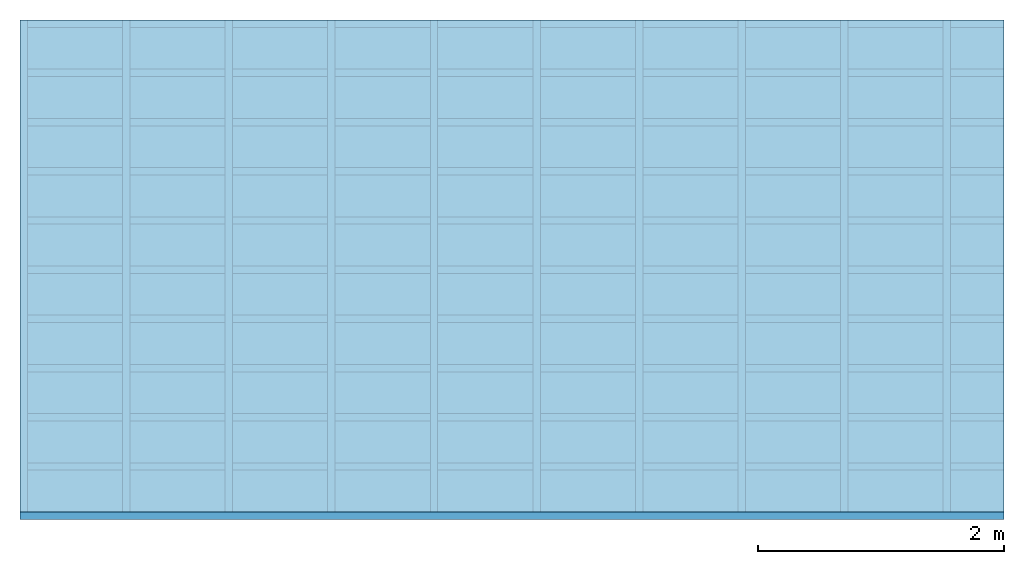
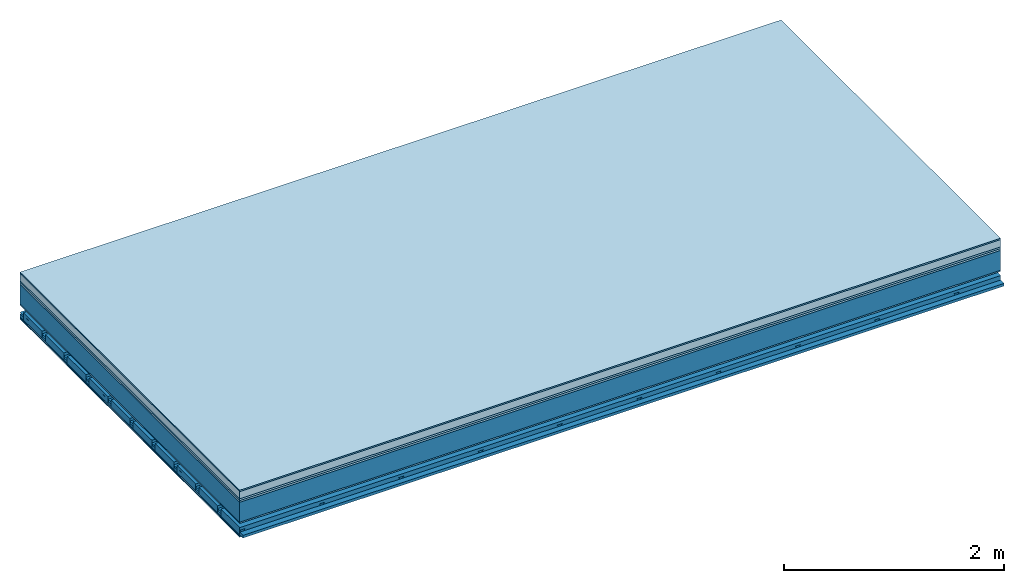
# One storey: 8 plates, 4 members, 1 element without a shape of its own.
"""IFC4 building model written with IfcOpenShell, lengths in metres."""

from ifc_helpers import new_model, si_unit, derived_unit, direction, frame, frame_2d, origin, origin_with_axes, place, context, project, spatial, polyline, rectangle, outline, extrude, material, layer, layer_set, type_object, element, aggregate, save


model = new_model("IFC4")

# Units and contexts
plan_context = context("Plan", 3, precision=1e-05, world=origin(), true_north=direction((0.0, 1.0)))
model_context = context("Model", 3, precision=1e-05, world=origin(), true_north=direction((0.0, 1.0)))
ifc_project = project(units=[si_unit("LENGTHUNIT", "METRE"), derived_unit("SOUNDPRESSUREUNIT", [(si_unit("PRESSUREUNIT", "PASCAL", prefix="MICRO"), 0)]), si_unit("ENERGYUNIT", "JOULE", prefix="MEGA"), si_unit("MASSUNIT", "GRAM", prefix="KILO"), derived_unit("THERMALTRANSMITTANCEUNIT", [(si_unit("POWERUNIT", "WATT"), 1), (si_unit("AREAUNIT", "SQUARE_METRE"), -1), (si_unit("THERMODYNAMICTEMPERATUREUNIT", "KELVIN"), -1)]), derived_unit("AREADENSITYUNIT", [(si_unit("MASSUNIT", "GRAM", prefix="KILO"), 1), (si_unit("AREAUNIT", "SQUARE_METRE"), -1)]), derived_unit("USERDEFINED", [(si_unit("ENERGYUNIT", "JOULE", prefix="MEGA"), 1), (si_unit("AREAUNIT", "SQUARE_METRE"), -1)])], contexts=[plan_context, model_context])

# Site, building, storey
site = spatial("IfcSite", under=ifc_project)
building_placement = place(None, origin())
building = spatial("IfcBuilding", under=site, at=building_placement)
storey_placement = place(building_placement, origin())
storey = spatial("IfcBuildingStorey", under=building, at=storey_placement)

# Slab, members, plates
ifc_material_1 = material(Category="11.013")
ifc_layer_1 = layer(ifc_material_1, 0.015, Name="Flooring")
ifc_material_2 = material(Name="Cement screed", Category="04.006")
ifc_layer_2 = layer(ifc_material_2, 0.08, Name="On-material")
ifc_material_3 = material(Name="Wood fiber generic product", Category="10.009")
ifc_layer_3 = layer(ifc_material_3, 0.02, Name="Impact sound insulation")
ifc_material_4 = material(Category="10.004")
ifc_layer_4 = layer(ifc_material_4, 0.02, Name="Additional insulation")
ifc_material_5 = material(Name="no composite action")
ifc_layer_5 = layer(ifc_material_5, 0.0, Name="Bond")
ifc_layer_6 = layer(None, 0.22, Name="Supporting structure")
ifc_material_6 = material(Name="of the art")
ifc_layer_7 = layer(ifc_material_6, 0.0, Name="Bond")
ifc_material_7 = material(Category="03.007")
ifc_layer_8 = layer(ifc_material_7, 0.015, Name="Lower layer 1")
ifc_layer_9 = layer(None, 0.095, Name="Coupling")
ifc_layer_10 = layer(None, 0.03, Name="Battens / profiles")
ifc_material_8 = material(Name="Plasterboard type A", Category="03.008")
ifc_layer_11 = layer(ifc_material_8, 0.0125, Name="Ceiling covering 1st layer")
ifc_layer_12 = layer(ifc_material_8, 0.0125, Name="Ceiling covering layer 2")
ifc_material_9 = material(Category="04.001")
ifc_layer_13 = layer(ifc_material_9, 0.003, Name="Surface / treatment")
ifc_layer_set = layer_set([ifc_layer_1, ifc_layer_2, ifc_layer_3, ifc_layer_4, ifc_layer_5, ifc_layer_6, ifc_layer_7, ifc_layer_8, ifc_layer_9, ifc_layer_10, ifc_layer_11, ifc_layer_12, ifc_layer_13])
slab_type = type_object("IfcSlabType", Name="A2164", PredefinedType="NOTDEFINED", material=ifc_layer_set)
slab_placement = place(None, frame((0.0, 0.0, 0.0), z_axis=(0.0, 0.0, -1.0), x_axis=(1.0, 0.0, 0.0)))
slab = element("IfcSlab", 1, at=slab_placement, inside=storey, type_object=slab_type, material=ifc_layer_set, Name="Slab #1")
ifc_material_10 = material(Name="Solid timber panel")
member_1_placement = place(slab_placement, origin())
member_1 = element("IfcMember", 2, at=member_1_placement, material=ifc_material_10, Name="Supporting structure", context=plan_context, shape_type="SweptSolid", body=[
    extrude(rectangle(XDim=1.0, YDim=0.22, at=frame_2d((0.5, 0.11), x_axis=(1.0, 0.0))), frame((0.0, 4.0, 0.135), z_axis=(0.0, -1.0, 0.0), x_axis=(1.0, 0.0, 0.0)), (0.0, 0.0, 1.0), 4.0),
    extrude(rectangle(XDim=1.0, YDim=0.22, at=frame_2d((0.5, 0.11), x_axis=(1.0, 0.0))), frame((1.0, 4.0, 0.135), z_axis=(0.0, -1.0, 0.0), x_axis=(1.0, 0.0, 0.0)), (0.0, 0.0, 1.0), 4.0),
    extrude(rectangle(XDim=1.0, YDim=0.22, at=frame_2d((0.5, 0.11), x_axis=(1.0, 0.0))), frame((2.0, 4.0, 0.135), z_axis=(0.0, -1.0, 0.0), x_axis=(1.0, 0.0, 0.0)), (0.0, 0.0, 1.0), 4.0),
    extrude(rectangle(XDim=1.0, YDim=0.22, at=frame_2d((0.5, 0.11), x_axis=(1.0, 0.0))), frame((3.0, 4.0, 0.135), z_axis=(0.0, -1.0, 0.0), x_axis=(1.0, 0.0, 0.0)), (0.0, 0.0, 1.0), 4.0),
    extrude(rectangle(XDim=1.0, YDim=0.22, at=frame_2d((0.5, 0.11), x_axis=(1.0, 0.0))), frame((4.0, 4.0, 0.135), z_axis=(0.0, -1.0, 0.0), x_axis=(1.0, 0.0, 0.0)), (0.0, 0.0, 1.0), 4.0),
    extrude(rectangle(XDim=1.0, YDim=0.22, at=frame_2d((0.5, 0.11), x_axis=(1.0, 0.0))), frame((5.0, 4.0, 0.135), z_axis=(0.0, -1.0, 0.0), x_axis=(1.0, 0.0, 0.0)), (0.0, 0.0, 1.0), 4.0),
    extrude(rectangle(XDim=1.0, YDim=0.22, at=frame_2d((0.5, 0.11), x_axis=(1.0, 0.0))), frame((6.0, 4.0, 0.135), z_axis=(0.0, -1.0, 0.0), x_axis=(1.0, 0.0, 0.0)), (0.0, 0.0, 1.0), 4.0),
    extrude(rectangle(XDim=1.0, YDim=0.22, at=frame_2d((0.5, 0.11), x_axis=(1.0, 0.0))), frame((7.0, 4.0, 0.135), z_axis=(0.0, -1.0, 0.0), x_axis=(1.0, 0.0, 0.0)), (0.0, 0.0, 1.0), 4.0),
])
ifc_material_11 = material()
member_2_placement = place(slab_placement, origin())
member_2 = element("IfcMember", 3, at=member_2_placement, material=ifc_material_11, Name="Coupling", context=plan_context, shape_type="SweptSolid", body=[
    extrude(outline(polyline([(0.0, 0.0), (0.06, 0.0), (0.04, 0.02), (0.02, 0.02), (0.0, 0.0)])), frame((0.0, 4.0, 0.445), z_axis=(0.0, -1.0, 0.0), x_axis=(1.0, 0.0, 0.0)), (0.0, 0.0, 1.0), 4.0),
    extrude(outline(polyline([(0.0, 0.0), (0.06, 0.0), (0.04, 0.02), (0.02, 0.02), (0.0, 0.0)])), frame((0.834, 4.0, 0.445), z_axis=(0.0, -1.0, 0.0), x_axis=(1.0, 0.0, 0.0)), (0.0, 0.0, 1.0), 4.0),
    extrude(outline(polyline([(0.0, 0.0), (0.06, 0.0), (0.04, 0.02), (0.02, 0.02), (0.0, 0.0)])), frame((1.668, 4.0, 0.445), z_axis=(0.0, -1.0, 0.0), x_axis=(1.0, 0.0, 0.0)), (0.0, 0.0, 1.0), 4.0),
    extrude(outline(polyline([(0.0, 0.0), (0.06, 0.0), (0.04, 0.02), (0.02, 0.02), (0.0, 0.0)])), frame((2.502, 4.0, 0.445), z_axis=(0.0, -1.0, 0.0), x_axis=(1.0, 0.0, 0.0)), (0.0, 0.0, 1.0), 4.0),
    extrude(outline(polyline([(0.0, 0.0), (0.06, 0.0), (0.04, 0.02), (0.02, 0.02), (0.0, 0.0)])), frame((3.336, 4.0, 0.445), z_axis=(0.0, -1.0, 0.0), x_axis=(1.0, 0.0, 0.0)), (0.0, 0.0, 1.0), 4.0),
    extrude(outline(polyline([(0.0, 0.0), (0.06, 0.0), (0.04, 0.02), (0.02, 0.02), (0.0, 0.0)])), frame((4.17, 4.0, 0.445), z_axis=(0.0, -1.0, 0.0), x_axis=(1.0, 0.0, 0.0)), (0.0, 0.0, 1.0), 4.0),
    extrude(outline(polyline([(0.0, 0.0), (0.06, 0.0), (0.04, 0.02), (0.02, 0.02), (0.0, 0.0)])), frame((5.004, 4.0, 0.445), z_axis=(0.0, -1.0, 0.0), x_axis=(1.0, 0.0, 0.0)), (0.0, 0.0, 1.0), 4.0),
    extrude(outline(polyline([(0.0, 0.0), (0.06, 0.0), (0.04, 0.02), (0.02, 0.02), (0.0, 0.0)])), frame((5.838, 4.0, 0.445), z_axis=(0.0, -1.0, 0.0), x_axis=(1.0, 0.0, 0.0)), (0.0, 0.0, 1.0), 4.0),
    extrude(outline(polyline([(0.0, 0.0), (0.06, 0.0), (0.04, 0.02), (0.02, 0.02), (0.0, 0.0)])), frame((6.672, 4.0, 0.445), z_axis=(0.0, -1.0, 0.0), x_axis=(1.0, 0.0, 0.0)), (0.0, 0.0, 1.0), 4.0),
    extrude(outline(polyline([(0.0, 0.0), (0.06, 0.0), (0.04, 0.02), (0.02, 0.02), (0.0, 0.0)])), frame((7.506, 4.0, 0.445), z_axis=(0.0, -1.0, 0.0), x_axis=(1.0, 0.0, 0.0)), (0.0, 0.0, 1.0), 4.0),
])
member_3_placement = place(slab_placement, origin())
member_3 = element("IfcMember", 4, at=member_3_placement, material=ifc_material_11, Name="Battens / profiles", context=plan_context, shape_type="SweptSolid", body=[
    extrude(rectangle(XDim=0.06, YDim=0.03, at=frame_2d((0.03, 0.015), x_axis=(1.0, 0.0))), frame((0.0, 0.0, 0.465), z_axis=(1.0, 0.0, 0.0), x_axis=(0.0, 1.0, 0.0)), (0.0, 0.0, 1.0), 8.0),
    extrude(rectangle(XDim=0.06, YDim=0.03, at=frame_2d((0.03, 0.015), x_axis=(1.0, 0.0))), frame((0.0, 0.4, 0.465), z_axis=(1.0, 0.0, 0.0), x_axis=(0.0, 1.0, 0.0)), (0.0, 0.0, 1.0), 8.0),
    extrude(rectangle(XDim=0.06, YDim=0.03, at=frame_2d((0.03, 0.015), x_axis=(1.0, 0.0))), frame((0.0, 0.8, 0.465), z_axis=(1.0, 0.0, 0.0), x_axis=(0.0, 1.0, 0.0)), (0.0, 0.0, 1.0), 8.0),
    extrude(rectangle(XDim=0.06, YDim=0.03, at=frame_2d((0.03, 0.015), x_axis=(1.0, 0.0))), frame((0.0, 1.2, 0.465), z_axis=(1.0, 0.0, 0.0), x_axis=(0.0, 1.0, 0.0)), (0.0, 0.0, 1.0), 8.0),
    extrude(rectangle(XDim=0.06, YDim=0.03, at=frame_2d((0.03, 0.015), x_axis=(1.0, 0.0))), frame((0.0, 1.6, 0.465), z_axis=(1.0, 0.0, 0.0), x_axis=(0.0, 1.0, 0.0)), (0.0, 0.0, 1.0), 8.0),
    extrude(rectangle(XDim=0.06, YDim=0.03, at=frame_2d((0.03, 0.015), x_axis=(1.0, 0.0))), frame((0.0, 2.0, 0.465), z_axis=(1.0, 0.0, 0.0), x_axis=(0.0, 1.0, 0.0)), (0.0, 0.0, 1.0), 8.0),
    extrude(rectangle(XDim=0.06, YDim=0.03, at=frame_2d((0.03, 0.015), x_axis=(1.0, 0.0))), frame((0.0, 2.4, 0.465), z_axis=(1.0, 0.0, 0.0), x_axis=(0.0, 1.0, 0.0)), (0.0, 0.0, 1.0), 8.0),
    extrude(rectangle(XDim=0.06, YDim=0.03, at=frame_2d((0.03, 0.015), x_axis=(1.0, 0.0))), frame((0.0, 2.8, 0.465), z_axis=(1.0, 0.0, 0.0), x_axis=(0.0, 1.0, 0.0)), (0.0, 0.0, 1.0), 8.0),
    extrude(rectangle(XDim=0.06, YDim=0.03, at=frame_2d((0.03, 0.015), x_axis=(1.0, 0.0))), frame((0.0, 3.2, 0.465), z_axis=(1.0, 0.0, 0.0), x_axis=(0.0, 1.0, 0.0)), (0.0, 0.0, 1.0), 8.0),
    extrude(rectangle(XDim=0.06, YDim=0.03, at=frame_2d((0.03, 0.015), x_axis=(1.0, 0.0))), frame((0.0, 3.6, 0.465), z_axis=(1.0, 0.0, 0.0), x_axis=(0.0, 1.0, 0.0)), (0.0, 0.0, 1.0), 8.0),
    extrude(rectangle(XDim=0.06, YDim=0.03, at=frame_2d((0.03, 0.015), x_axis=(1.0, 0.0))), frame((0.0, 4.0, 0.465), z_axis=(1.0, 0.0, 0.0), x_axis=(0.0, 1.0, 0.0)), (0.0, 0.0, 1.0), 8.0),
])
ifc_material_12 = material()
member_4_placement = place(slab_placement, origin())
member_4 = element("IfcMember", 5, at=member_4_placement, material=ifc_material_12, Name="Cavity", context=plan_context, shape_type="SweptSolid", body=[
    extrude(rectangle(XDim=0.34, YDim=0.08, at=frame_2d((0.17, 0.04), x_axis=(1.0, 0.0))), frame((0.0, 0.06, 0.415), z_axis=(1.0, 0.0, 0.0), x_axis=(0.0, 1.0, 0.0)), (0.0, 0.0, 1.0), 8.0),
    extrude(rectangle(XDim=0.34, YDim=0.08, at=frame_2d((0.17, 0.04), x_axis=(1.0, 0.0))), frame((0.0, 0.46, 0.415), z_axis=(1.0, 0.0, 0.0), x_axis=(0.0, 1.0, 0.0)), (0.0, 0.0, 1.0), 8.0),
    extrude(rectangle(XDim=0.34, YDim=0.08, at=frame_2d((0.17, 0.04), x_axis=(1.0, 0.0))), frame((0.0, 0.86, 0.415), z_axis=(1.0, 0.0, 0.0), x_axis=(0.0, 1.0, 0.0)), (0.0, 0.0, 1.0), 8.0),
    extrude(rectangle(XDim=0.34, YDim=0.08, at=frame_2d((0.17, 0.04), x_axis=(1.0, 0.0))), frame((0.0, 1.26, 0.415), z_axis=(1.0, 0.0, 0.0), x_axis=(0.0, 1.0, 0.0)), (0.0, 0.0, 1.0), 8.0),
    extrude(rectangle(XDim=0.34, YDim=0.08, at=frame_2d((0.17, 0.04), x_axis=(1.0, 0.0))), frame((0.0, 1.66, 0.415), z_axis=(1.0, 0.0, 0.0), x_axis=(0.0, 1.0, 0.0)), (0.0, 0.0, 1.0), 8.0),
    extrude(rectangle(XDim=0.34, YDim=0.08, at=frame_2d((0.17, 0.04), x_axis=(1.0, 0.0))), frame((0.0, 2.06, 0.415), z_axis=(1.0, 0.0, 0.0), x_axis=(0.0, 1.0, 0.0)), (0.0, 0.0, 1.0), 8.0),
    extrude(rectangle(XDim=0.34, YDim=0.08, at=frame_2d((0.17, 0.04), x_axis=(1.0, 0.0))), frame((0.0, 2.46, 0.415), z_axis=(1.0, 0.0, 0.0), x_axis=(0.0, 1.0, 0.0)), (0.0, 0.0, 1.0), 8.0),
    extrude(rectangle(XDim=0.34, YDim=0.08, at=frame_2d((0.17, 0.04), x_axis=(1.0, 0.0))), frame((0.0, 2.86, 0.415), z_axis=(1.0, 0.0, 0.0), x_axis=(0.0, 1.0, 0.0)), (0.0, 0.0, 1.0), 8.0),
    extrude(rectangle(XDim=0.34, YDim=0.08, at=frame_2d((0.17, 0.04), x_axis=(1.0, 0.0))), frame((0.0, 3.26, 0.415), z_axis=(1.0, 0.0, 0.0), x_axis=(0.0, 1.0, 0.0)), (0.0, 0.0, 1.0), 8.0),
    extrude(rectangle(XDim=0.34, YDim=0.08, at=frame_2d((0.17, 0.04), x_axis=(1.0, 0.0))), frame((0.0, 3.66, 0.415), z_axis=(1.0, 0.0, 0.0), x_axis=(0.0, 1.0, 0.0)), (0.0, 0.0, 1.0), 8.0),
])
plate_1_placement = place(slab_placement, origin())
plate_1 = element("IfcPlate", 6, at=plate_1_placement, material=ifc_material_1, Name="Flooring", context=plan_context, shape_type="SweptSolid", body=[
    extrude(rectangle(XDim=8.0, YDim=4.0, at=frame_2d((4.0, 2.0), x_axis=(1.0, 0.0))), origin_with_axes(), (0.0, 0.0, 1.0), 0.015),
])
plate_2_placement = place(slab_placement, origin())
plate_2 = element("IfcPlate", 7, at=plate_2_placement, material=ifc_material_2, Name="On-material", context=plan_context, shape_type="SweptSolid", body=[
    extrude(rectangle(XDim=8.0, YDim=4.0, at=frame_2d((4.0, 2.0), x_axis=(1.0, 0.0))), frame((0.0, 0.0, 0.015), z_axis=(0.0, 0.0, 1.0), x_axis=(1.0, 0.0, 0.0)), (0.0, 0.0, 1.0), 0.08),
])
plate_3_placement = place(slab_placement, origin())
plate_3 = element("IfcPlate", 8, at=plate_3_placement, material=ifc_material_3, Name="Impact sound insulation", context=plan_context, shape_type="SweptSolid", body=[
    extrude(rectangle(XDim=8.0, YDim=4.0, at=frame_2d((4.0, 2.0), x_axis=(1.0, 0.0))), frame((0.0, 0.0, 0.095), z_axis=(0.0, 0.0, 1.0), x_axis=(1.0, 0.0, 0.0)), (0.0, 0.0, 1.0), 0.02),
])
plate_4_placement = place(slab_placement, origin())
plate_4 = element("IfcPlate", 9, at=plate_4_placement, material=ifc_material_4, Name="Additional insulation", context=plan_context, shape_type="SweptSolid", body=[
    extrude(rectangle(XDim=8.0, YDim=4.0, at=frame_2d((4.0, 2.0), x_axis=(1.0, 0.0))), frame((0.0, 0.0, 0.115), z_axis=(0.0, 0.0, 1.0), x_axis=(1.0, 0.0, 0.0)), (0.0, 0.0, 1.0), 0.02),
])
plate_5_placement = place(slab_placement, origin())
plate_5 = element("IfcPlate", 10, at=plate_5_placement, material=ifc_material_7, Name="Lower layer 1", context=plan_context, shape_type="SweptSolid", body=[
    extrude(rectangle(XDim=8.0, YDim=4.0, at=frame_2d((4.0, 2.0), x_axis=(1.0, 0.0))), frame((0.0, 0.0, 0.355), z_axis=(0.0, 0.0, 1.0), x_axis=(1.0, 0.0, 0.0)), (0.0, 0.0, 1.0), 0.015),
])
plate_6_placement = place(slab_placement, origin())
plate_6 = element("IfcPlate", 11, at=plate_6_placement, material=ifc_material_8, Name="Ceiling covering 1st layer", context=plan_context, shape_type="SweptSolid", body=[
    extrude(rectangle(XDim=8.0, YDim=4.0, at=frame_2d((4.0, 2.0), x_axis=(1.0, 0.0))), frame((0.0, 0.0, 0.495), z_axis=(0.0, 0.0, 1.0), x_axis=(1.0, 0.0, 0.0)), (0.0, 0.0, 1.0), 0.0125),
])
plate_7_placement = place(slab_placement, origin())
plate_7 = element("IfcPlate", 12, at=plate_7_placement, material=ifc_material_8, Name="Ceiling covering layer 2", context=plan_context, shape_type="SweptSolid", body=[
    extrude(rectangle(XDim=8.0, YDim=4.0, at=frame_2d((4.0, 2.0), x_axis=(1.0, 0.0))), frame((0.0, 0.0, 0.5075), z_axis=(0.0, 0.0, 1.0), x_axis=(1.0, 0.0, 0.0)), (0.0, 0.0, 1.0), 0.0125),
])
plate_8_placement = place(slab_placement, origin())
plate_8 = element("IfcPlate", 13, at=plate_8_placement, material=ifc_material_9, Name="Surface / treatment", context=plan_context, shape_type="SweptSolid", body=[
    extrude(rectangle(XDim=8.0, YDim=4.0, at=frame_2d((4.0, 2.0), x_axis=(1.0, 0.0))), frame((0.0, 0.0, 0.52), z_axis=(0.0, 0.0, 1.0), x_axis=(1.0, 0.0, 0.0)), (0.0, 0.0, 1.0), 0.003),
])
aggregate(slab, [plate_1, plate_2, plate_3, plate_4, member_1, plate_5, member_2, member_3, member_4, plate_6, plate_7, plate_8])

save(model, "model.ifc")
